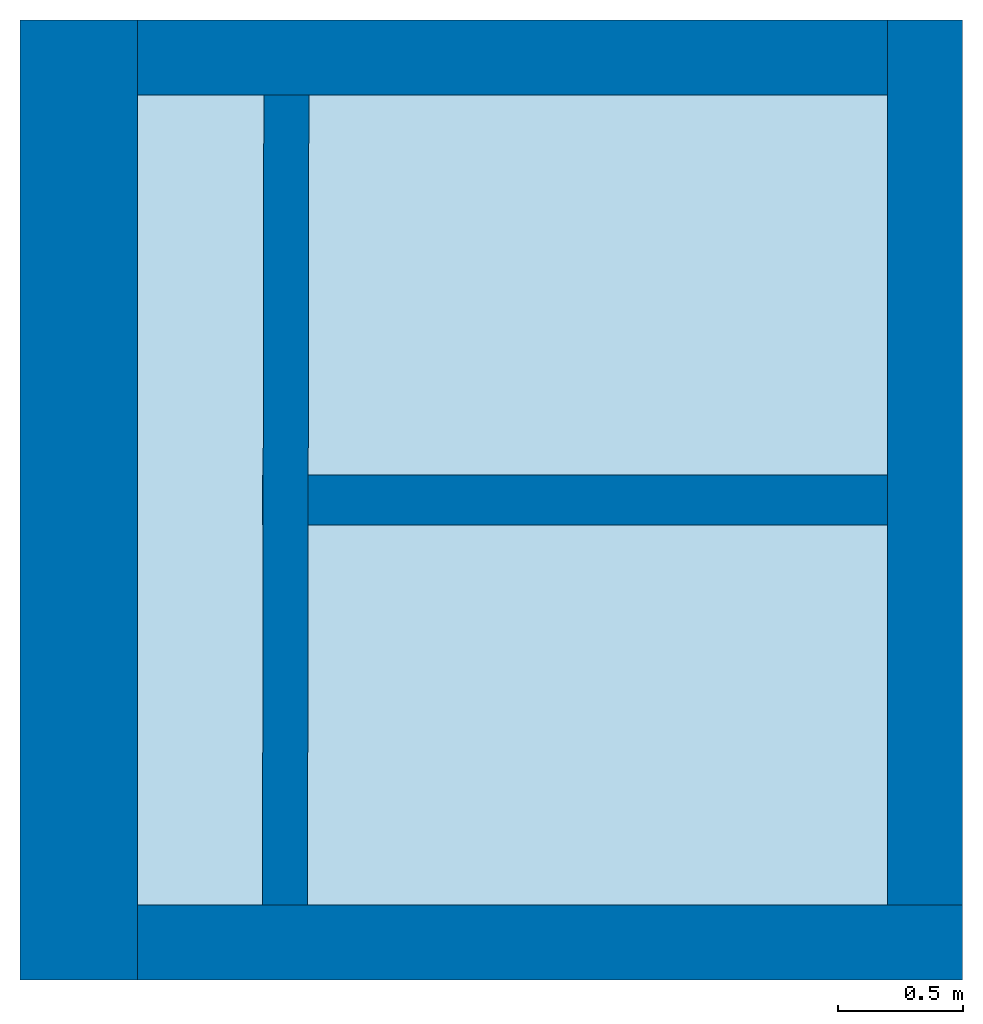
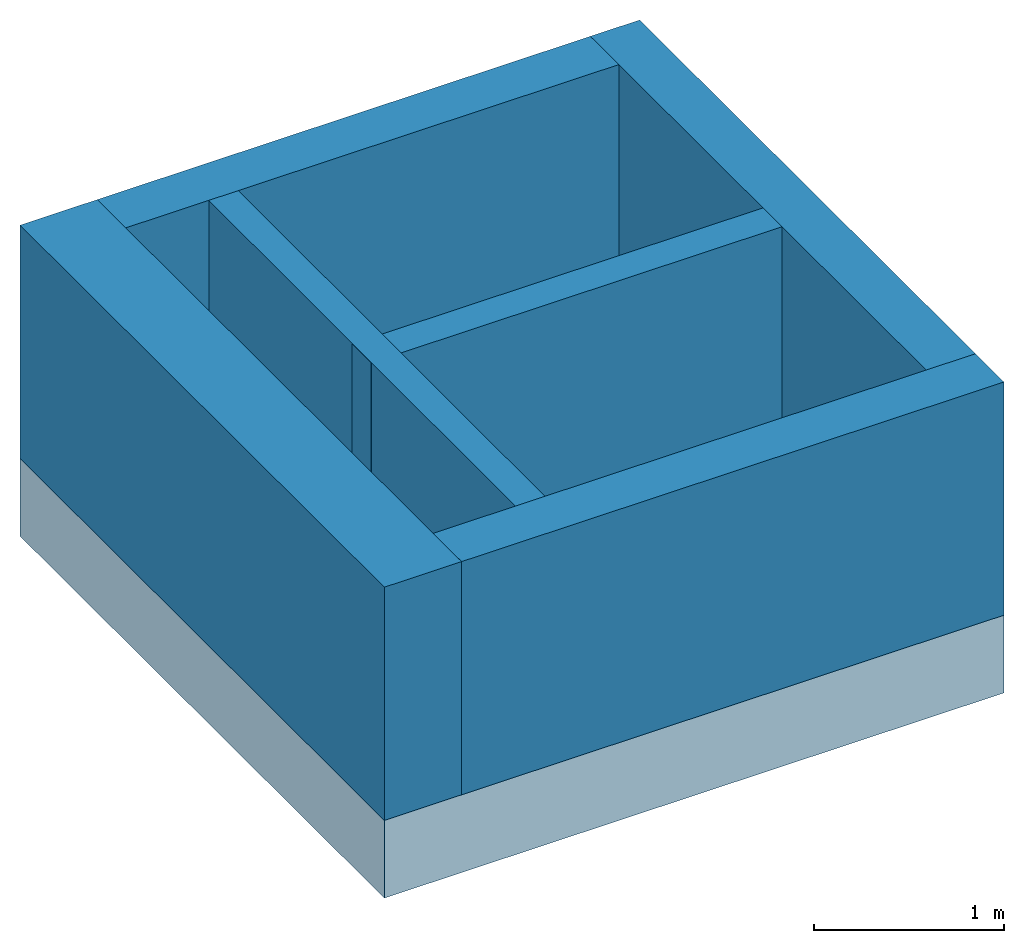
# One storey: 6 walls, 1 footing.
"""IFC4 building model written with IfcOpenShell, lengths in metres."""

from ifc_helpers import new_model, entity, si_unit, converted_unit, derived_unit, direction, frame, origin_with_axes, place, context, subcontext, project, spatial, polygons, material, type_object, element, save


model = new_model("IFC4")

# Units and contexts
model_context = context("Model", 3, precision=1e-05, world=origin_with_axes(), true_north=direction((0.0, 1.0)))
body_context = subcontext(model_context, "Body", "Model", "MODEL_VIEW")
ifc_project = project(units=[si_unit("LENGTHUNIT", "METRE"), si_unit("AREAUNIT", "SQUARE_METRE"), si_unit("VOLUMEUNIT", "CUBIC_METRE"), converted_unit("PLANEANGLEUNIT", "DEGREE", entity("IfcPlaneAngleMeasure", 0.0174532925199433), si_unit("PLANEANGLEUNIT", "RADIAN"), dimensions=[0, 0, 0, 0, 0, 0, 0]), converted_unit("TIMEUNIT", "Year", entity("IfcTimeMeasure", 31557600.0), si_unit("TIMEUNIT", "SECOND"), dimensions=[0, 0, 1, 0, 0, 0, 0]), si_unit("MASSUNIT", "GRAM", prefix="KILO"), si_unit("THERMODYNAMICTEMPERATUREUNIT", "DEGREE_CELSIUS"), si_unit("LUMINOUSINTENSITYUNIT", "LUMEN"), si_unit("ENERGYUNIT", "JOULE", prefix="MEGA"), derived_unit("THERMALCONDUCTANCEUNIT", [(si_unit("POWERUNIT", "WATT"), 1), (si_unit("LENGTHUNIT", "METRE"), -1), (si_unit("THERMODYNAMICTEMPERATUREUNIT", "KELVIN"), -1)]), derived_unit("SPECIFICHEATCAPACITYUNIT", [(si_unit("ENERGYUNIT", "JOULE"), 1), (si_unit("MASSUNIT", "GRAM", prefix="KILO"), -1), (si_unit("THERMODYNAMICTEMPERATUREUNIT", "KELVIN"), -1)]), derived_unit("MASSDENSITYUNIT", [(si_unit("MASSUNIT", "GRAM", prefix="KILO"), 1), (si_unit("VOLUMEUNIT", "CUBIC_METRE"), -1)])], contexts=[model_context])

# Site, building, storey
site_placement = place(None, origin_with_axes())
site = spatial("IfcSite", under=ifc_project, at=site_placement, CompositionType="ELEMENT")
building_placement = place(site_placement, origin_with_axes())
building = spatial("IfcBuilding", under=site, at=building_placement, CompositionType="ELEMENT")
storey_placement = place(building_placement, frame((0.0, 0.0, -6.0), z_axis=(0.0, 0.0, 1.0), x_axis=(1.0, 0.0, 0.0)))
storey = spatial("IfcBuildingStorey", under=building, at=storey_placement, Name="FU", CompositionType="ELEMENT", Elevation=-6.0)

# Footing
ifc_material_1 = material(Name="Stahlbeton Decke")
footing_type = type_object("IfcFootingType", Name="Stahlbeton Decke 500", PredefinedType="NOTDEFINED")
footing_placement = place(storey_placement, frame((27.988, 6.934999945467553, 1.5), z_axis=(0.0, 0.0, 1.0), x_axis=(1.0, 0.0, 0.0)))
element("IfcFooting", 1, at=footing_placement, inside=storey, type_object=footing_type, material=ifc_material_1, Name="Decke-001", PredefinedType="NOTDEFINED", context=body_context, shape_type="Tessellation", body=[
    polygons([(0.0, 0.0, 0.0), (0.0, 0.0, -0.5), (3.770000000000003, 0.0, -0.5), (3.770000000000003, 0.0, 0.0), (0.0, 3.840000000000003, 0.0), (0.0, 3.840000000000003, -0.5), (3.770000000000003, 3.840000000000003, -0.5), (3.770000000000003, 3.840000000000003, 0.0)], [[[1, 2, 3, 4]], [[5, 6, 2, 1]], [[3, 2, 6, 7]], [[4, 3, 7, 8]], [[5, 1, 4, 8]], [[8, 7, 6, 5]]], closed=True),
])

# Walls
ifc_material_2 = material(Name="Stahlbeton")
wall_type_1 = type_object("IfcWallType", Name="Stahlbeton 300", PredefinedType="NOTDEFINED")
wall_1_placement = place(storey_placement, frame((31.758, 10.77499994546756, 1.5), z_axis=(0.0, 0.0, 1.0), x_axis=(-1.0, 0.0, 0.0)))
element("IfcWall", 2, at=wall_1_placement, inside=storey, type_object=wall_type_1, material=ifc_material_2, Name="Wand-003", PredefinedType="NOTDEFINED", context=body_context, shape_type="Tessellation", body=[
    polygons([(3.300000000000001, 0.2999999999999989, 0.0), (3.300000000000001, 0.0, 0.0), (0.3000000000000007, 0.0, 0.0), (0.3000000000000007, 0.3000000000000007, 0.0), (3.300000000000001, 0.3000000000000007, 1.5), (3.300000000000001, 0.0, 1.5), (0.3000000000000007, 0.0, 1.5), (0.3000000000000007, 0.3000000000000007, 1.5)], [[[1, 2, 3, 4]], [[2, 1, 5, 6]], [[2, 6, 7, 3]], [[8, 4, 3, 7]], [[5, 1, 4, 8]], [[6, 5, 8, 7]]], closed=True),
])
wall_2_placement = place(storey_placement, frame((27.988, 6.934999945467553, 1.5), z_axis=(0.0, 0.0, 1.0), x_axis=(1.0, 0.0, 0.0)))
element("IfcWall", 3, at=wall_2_placement, inside=storey, type_object=wall_type_1, material=ifc_material_2, Name="Wand-001", PredefinedType="NOTDEFINED", context=body_context, shape_type="Tessellation", body=[
    polygons([(3.770000000000003, 0.3000000000000016, 0.0), (3.770000000000003, 0.0, 0.0), (0.4699999999999989, 0.0, 0.0), (0.4699999999999989, 0.2999999999999998, 0.0), (3.770000000000003, 0.3000000000000025, 1.5), (3.770000000000003, 0.0, 1.5), (0.4699999999999989, 0.0, 1.5), (0.4699999999999989, 0.2999999999999998, 1.5)], [[[1, 2, 3, 4]], [[2, 1, 5, 6]], [[2, 6, 7, 3]], [[8, 4, 3, 7]], [[5, 1, 4, 8]], [[6, 5, 8, 7]]], closed=True),
])
wall_3_placement = place(storey_placement, frame((31.75800000000001, 6.934999945467552, 1.5), z_axis=(0.0, 0.0, 1.0), x_axis=(0.0, 1.0, 0.0)))
element("IfcWall", 4, at=wall_3_placement, inside=storey, type_object=wall_type_1, material=ifc_material_2, Name="Wand-002", PredefinedType="NOTDEFINED", context=body_context, shape_type="Tessellation", body=[
    polygons([(3.840000000000005, 0.2999999999999972, 0.0), (3.840000000000003, 0.0, 0.0), (0.2999999999999998, 0.0, 0.0), (0.2999999999999998, 0.3000000000000007, 0.0), (3.840000000000005, 0.2999999999999972, 1.5), (3.840000000000003, 0.0, 1.5), (0.2999999999999998, 0.0, 1.5), (0.2999999999999998, 0.3000000000000007, 1.5)], [[[1, 2, 3, 4]], [[2, 1, 5, 6]], [[2, 6, 7, 3]], [[8, 4, 3, 7]], [[5, 1, 4, 8]], [[6, 5, 8, 7]]], closed=True),
])
wall_type_2 = type_object("IfcWallType", Name="Stahlbeton 470", PredefinedType="NOTDEFINED")
wall_4_placement = place(storey_placement, frame((27.988, 10.77499994546756, 1.5), z_axis=(0.0, 0.0, 1.0), x_axis=(0.0, -1.0, 0.0)))
element("IfcWall", 5, at=wall_4_placement, inside=storey, type_object=wall_type_2, material=ifc_material_2, Name="Wand-003", PredefinedType="NOTDEFINED", context=body_context, shape_type="Tessellation", body=[
    polygons([(3.840000000000003, 0.4699999999999989, 0.0), (3.840000000000003, 0.0, 0.0), (0.0, 0.0, 0.0), (0.0, 0.4699999999999989, 0.0), (3.840000000000003, 0.4699999999999989, 1.5), (3.840000000000003, 0.0, 1.5), (0.0, 0.0, 1.5), (0.0, 0.4699999999999989, 1.5)], [[[1, 2, 3, 4]], [[2, 1, 5, 6]], [[2, 6, 7, 3]], [[8, 4, 3, 7]], [[5, 1, 4, 8]], [[6, 5, 8, 7]]], closed=True),
])
wall_type_3 = type_object("IfcWallType", Name="Stahlbeton 200", PredefinedType="NOTDEFINED")
wall_5_placement = place(storey_placement, frame((28.958, 8.854999945467554, 1.5), z_axis=(0.0, 0.0, 1.0), x_axis=(1.0, 0.0, 0.0)))
element("IfcWall", 6, at=wall_5_placement, inside=storey, type_object=wall_type_3, material=ifc_material_2, Name="Wand-001", PredefinedType="NOTDEFINED", context=body_context, shape_type="Tessellation", body=[
    polygons([(0.002822856202016055, 0.09999999999999964, 0.0), (0.002494588915904927, -0.09999999999999964, 0.0), (0.0, -0.09999999999999964, 0.0), (0.0, 0.09999999999999964, 0.0), (0.002822856202016055, 0.09999999999999964, 1.5), (0.002494588915904927, -0.09999999999999964, 1.5), (0.0, -0.09999999999999964, 1.5), (0.0, 0.09999999999999964, 1.5)], [[[1, 2, 3, 4]], [[2, 1, 5, 6]], [[2, 6, 7, 3]], [[8, 4, 3, 7]], [[5, 1, 4, 8]], [[6, 5, 8, 7]]], closed=True),
    polygons([(2.500000000000004, 0.09999999999999964, 0.0), (2.500000000000004, -0.09999999999999964, 0.0), (0.1824948313744166, -0.09999999999999964, 0.0), (0.1828230986605277, 0.09999999999999964, 0.0), (2.500000000000004, 0.09999999999999964, 1.5), (2.500000000000004, -0.09999999999999964, 1.5), (0.1824948313744166, -0.09999999999999964, 1.5), (0.1828230986605277, 0.09999999999999964, 1.5)], [[[1, 2, 3, 4]], [[2, 1, 5, 6]], [[2, 6, 7, 3]], [[8, 4, 3, 7]], [[5, 1, 4, 8]], [[6, 5, 8, 7]]], closed=True),
])
wall_type_4 = type_object("IfcWallType", Name="Stahlbeton 180", PredefinedType="NOTDEFINED")
wall_6_placement = place(storey_placement, frame((29.13750759907084, 6.934999945467553, 1.5), z_axis=(0.0, 0.0, 1.0), x_axis=(0.001641334219673882, 0.9999986530100825, 0.0)))
element("IfcWall", 7, at=wall_6_placement, inside=storey, type_object=wall_type_4, material=ifc_material_2, Name="Wand-001", PredefinedType="NOTDEFINED", context=body_context, shape_type="Tessellation", body=[
    polygons([(0.2997049635400222, 0.1799999999999997, 0.0), (3.539709327793235, 0.1800000000000068, 0.0), (3.540004768350732, 0.0, 0.0), (0.3000004040975197, 0.0, 0.0), (0.2997049635400222, 0.1799999999999997, 1.5), (3.539709327793235, 0.1800000000000068, 1.5), (3.540004768350732, 0.0, 1.5), (0.3000004040975197, 0.0, 1.5)], [[[1, 2, 3, 4]], [[5, 6, 2, 1]], [[7, 3, 2, 6]], [[4, 3, 7, 8]], [[8, 5, 1, 4]], [[8, 7, 6, 5]]], closed=True),
])

save(model, "model.ifc")
